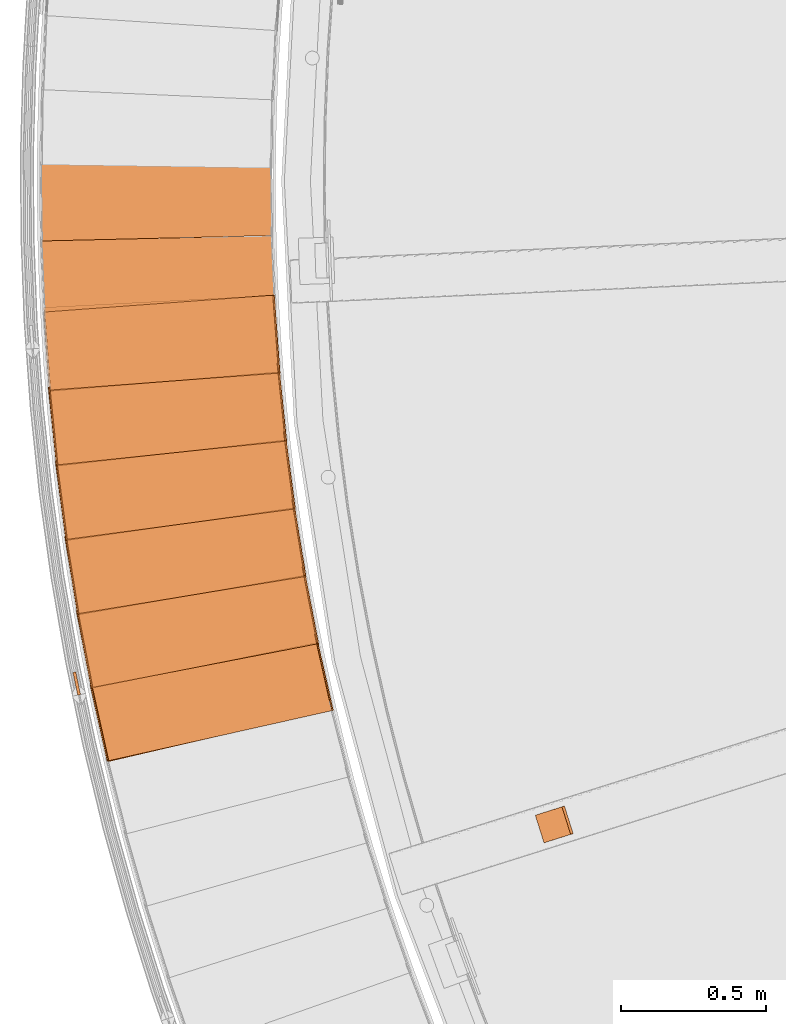
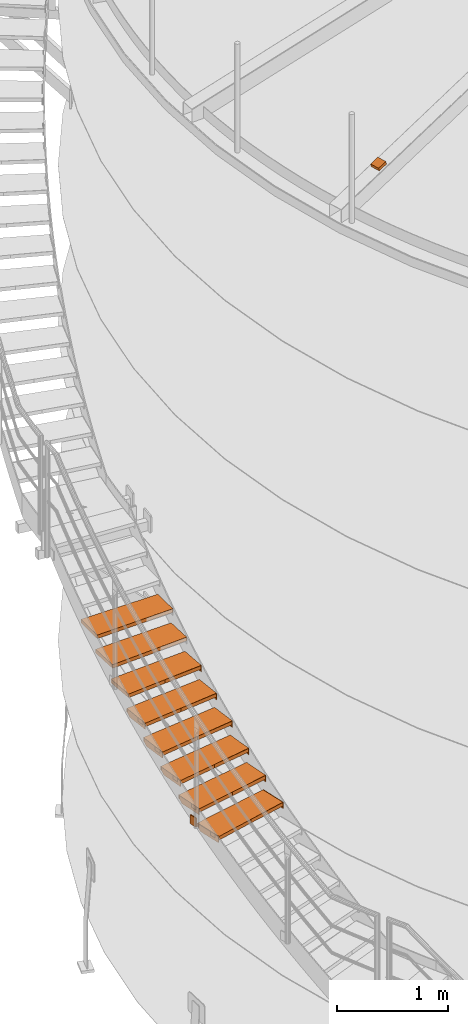
# One storey, part 52 of 126: 27 proxies.
"""IFC2X3 building model written with IfcOpenShell, lengths in millimetres."""

from ifc_helpers import new_model, si_unit, origin, origin_with_axes, place, context, project, spatial, faceted_brep, material, element, save


model = new_model("IFC2X3")

# Units and contexts
context_of_model_1 = context(None, 3, precision=0.1, world=origin())
context_of_model_2 = context(None, 3, precision=0.1, world=origin())
ifc_project = project(units=[si_unit("LENGTHUNIT", "METRE", prefix="MILLI"), si_unit("AREAUNIT", "SQUARE_METRE", prefix="CENTI"), si_unit("VOLUMEUNIT", "CUBIC_METRE", prefix="CENTI"), si_unit("MASSUNIT", "GRAM", prefix="KILO")], contexts=[context_of_model_1, context_of_model_2])

# Site, building, storey
site_placement = place(None, origin_with_axes())
site = spatial("IfcSite", under=ifc_project, at=site_placement, CompositionType="ELEMENT")
building_placement = place(site_placement, origin_with_axes())
building = spatial("IfcBuilding", under=site, at=building_placement, CompositionType="ELEMENT")
storey_placement = place(building_placement, origin_with_axes())
storey = spatial("IfcBuildingStorey", under=building, at=storey_placement, CompositionType="ELEMENT")

# Proxies
ifc_material_1 = material(Name="HOLZ")
proxy_1_placement = place(storey_placement, origin_with_axes())
element("IfcBuildingElementProxy", 1, at=proxy_1_placement, inside=storey, material=ifc_material_1, context=context_of_model_2, shape_type="Brep", body=[
    faceted_brep([(-642.1313, 6282.6158, 3810.5375), (-636.9506, 6256.8076, 3810.5375), (-631.6929, 6231.015, 3810.5375), (-626.3582, 6205.2382, 3810.5375), (-620.9466, 6179.4774, 3810.5375), (-615.4581, 6153.7329, 3810.5375), (-609.8927, 6128.0049, 3810.5375), (-604.2506, 6102.2937, 3810.5375), (-598.5317, 6076.5994, 3810.5375), (-592.7362, 6050.9222, 3810.5375), (-586.864, 6025.2625, 3810.5375), (-580.9152, 5999.6205, 3810.5375), (198.1176, 6181.5762, 3810.5375), (192.1105, 6207.4893, 3810.5375), (186.1894, 6233.4223, 3810.5375), (180.3543, 6259.3747, 3810.5375), (174.6055, 6285.3464, 3810.5375), (168.9428, 6311.337, 3810.5375), (163.3664, 6337.3462, 3810.5375), (157.8763, 6363.3738, 3810.5375), (152.4726, 6389.4195, 3810.5375), (147.1553, 6415.483, 3810.5375), (141.9246, 6441.5639, 3810.5375), (-642.1313, 6282.6158, 3770.5375), (141.9246, 6441.5639, 3770.5375), (147.1553, 6415.483, 3770.5375), (152.4726, 6389.4195, 3770.5375), (157.8763, 6363.3738, 3770.5375), (163.3664, 6337.3462, 3770.5375), (168.9428, 6311.337, 3770.5375), (174.6055, 6285.3464, 3770.5375), (180.3543, 6259.3747, 3770.5375), (186.1894, 6233.4223, 3770.5375), (192.1105, 6207.4893, 3770.5375), (198.1176, 6181.5762, 3770.5375), (-580.9152, 5999.6205, 3770.5375), (-586.864, 6025.2625, 3770.5375), (-592.7362, 6050.9222, 3770.5375), (-598.5317, 6076.5994, 3770.5375), (-604.2506, 6102.2937, 3770.5375), (-609.8927, 6128.0049, 3770.5375), (-615.4581, 6153.7329, 3770.5375), (-620.9466, 6179.4774, 3770.5375), (-626.3582, 6205.2382, 3770.5375), (-631.6929, 6231.015, 3770.5375), (-636.9506, 6256.8076, 3770.5375)], [[[0, 1, 2, 3, 4, 5, 6, 7, 8, 9, 10, 11, 12, 13, 14, 15, 16, 17, 18, 19, 20, 21, 22]], [[23, 24, 25, 26, 27, 28, 29, 30, 31, 32, 33, 34, 35, 36, 37, 38, 39, 40, 41, 42, 43, 44, 45]], [[0, 23, 45, 1]], [[1, 45, 44, 2]], [[2, 44, 43, 3]], [[3, 43, 42, 4]], [[4, 42, 41, 5]], [[5, 41, 40, 6]], [[6, 40, 39, 7]], [[7, 39, 38, 8]], [[8, 38, 37, 9]], [[9, 37, 36, 10]], [[10, 36, 35, 11]], [[11, 35, 34, 12]], [[12, 34, 33, 13]], [[13, 33, 32, 14]], [[14, 32, 31, 15]], [[15, 31, 30, 16]], [[16, 30, 29, 17]], [[17, 29, 28, 18]], [[18, 28, 27, 19]], [[19, 27, 26, 20]], [[20, 26, 25, 21]], [[21, 25, 24, 22]], [[22, 24, 23, 0]]]),
])
proxy_2_placement = place(storey_placement, origin_with_axes())
element("IfcBuildingElementProxy", 2, at=proxy_2_placement, inside=storey, material=ifc_material_1, context=context_of_model_2, shape_type="Brep", body=[
    faceted_brep([(-689.0808, 6537.8783, 3983.7438), (-684.662, 6511.9288, 3983.7438), (-680.1657, 6485.9926, 3983.7438), (-675.592, 6460.0699, 3983.7438), (-670.941, 6434.161, 3983.7438), (-666.2126, 6408.2662, 3983.7438), (-661.4069, 6382.3855, 3983.7438), (-656.524, 6356.5193, 3983.7438), (-651.5639, 6330.6678, 3983.7438), (-646.5266, 6304.8312, 3983.7438), (-641.4123, 6279.0098, 3983.7438), (-636.2208, 6253.2038, 3983.7438), (147.8301, 6412.1509, 3983.7438), (142.5883, 6438.2297, 3983.7438), (137.4331, 6464.3256, 3983.7438), (132.3644, 6490.4386, 3983.7438), (127.3825, 6516.5682, 3983.7438), (122.4872, 6542.7142, 3983.7438), (117.6788, 6568.8763, 3983.7438), (112.9572, 6595.0542, 3983.7438), (108.3224, 6621.2477, 3983.7438), (103.7746, 6647.4563, 3983.7438), (99.3138, 6673.68, 3983.7438), (-689.0808, 6537.8783, 3943.7438), (99.3138, 6673.68, 3943.7438), (103.7746, 6647.4563, 3943.7438), (108.3224, 6621.2477, 3943.7438), (112.9572, 6595.0542, 3943.7438), (117.6788, 6568.8763, 3943.7438), (122.4872, 6542.7142, 3943.7438), (127.3825, 6516.5682, 3943.7438), (132.3644, 6490.4386, 3943.7438), (137.4331, 6464.3256, 3943.7438), (142.5883, 6438.2297, 3943.7438), (147.8301, 6412.1509, 3943.7438), (-636.2208, 6253.2038, 3943.7438), (-641.4123, 6279.0098, 3943.7438), (-646.5266, 6304.8312, 3943.7438), (-651.5639, 6330.6678, 3943.7438), (-656.524, 6356.5193, 3943.7438), (-661.4069, 6382.3855, 3943.7438), (-666.2126, 6408.2662, 3943.7438), (-670.941, 6434.161, 3943.7438), (-675.592, 6460.0699, 3943.7438), (-680.1657, 6485.9926, 3943.7438), (-684.662, 6511.9288, 3943.7438)], [[[0, 1, 2, 3, 4, 5, 6, 7, 8, 9, 10, 11, 12, 13, 14, 15, 16, 17, 18, 19, 20, 21, 22]], [[23, 24, 25, 26, 27, 28, 29, 30, 31, 32, 33, 34, 35, 36, 37, 38, 39, 40, 41, 42, 43, 44, 45]], [[0, 23, 45, 1]], [[1, 45, 44, 2]], [[2, 44, 43, 3]], [[3, 43, 42, 4]], [[4, 42, 41, 5]], [[5, 41, 40, 6]], [[6, 40, 39, 7]], [[7, 39, 38, 8]], [[8, 38, 37, 9]], [[9, 37, 36, 10]], [[10, 36, 35, 11]], [[11, 35, 34, 12]], [[12, 34, 33, 13]], [[13, 33, 32, 14]], [[14, 32, 31, 15]], [[15, 31, 30, 16]], [[16, 30, 29, 17]], [[17, 29, 28, 18]], [[18, 28, 27, 19]], [[19, 27, 26, 20]], [[20, 26, 25, 21]], [[21, 25, 24, 22]], [[22, 24, 23, 0]]]),
])
proxy_3_placement = place(storey_placement, origin_with_axes())
element("IfcBuildingElementProxy", 3, at=proxy_3_placement, inside=storey, material=ifc_material_1, context=context_of_model_2, shape_type="Brep", body=[
    faceted_brep([(-728.4966, 6794.4121, 4156.95), (-724.8435, 6768.3438, 4156.95), (-721.1126, 6742.2865, 4156.95), (-717.3039, 6716.2404, 4156.95), (-713.4175, 6690.2059, 4156.95), (-709.4533, 6664.183, 4156.95), (-705.4115, 6638.1721, 4156.95), (-701.292, 6612.1734, 4156.95), (-697.095, 6586.1871, 4156.95), (-692.8203, 6560.2135, 4156.95), (-688.4682, 6534.2527, 4156.95), (-684.0386, 6508.3051, 4156.95), (104.351, 6644.1059, 4156.95), (99.8791, 6670.3276, 4156.95), (95.4942, 6696.564, 4156.95), (91.1963, 6722.8149, 4156.95), (86.9856, 6749.0798, 4156.95), (82.8621, 6775.3586, 4156.95), (78.8258, 6801.6509, 4156.95), (74.8767, 6827.9564, 4156.95), (71.015, 6854.2749, 4156.95), (67.2405, 6880.6061, 4156.95), (63.5535, 6906.9496, 4156.95), (-728.4966, 6794.4121, 4116.95), (63.5535, 6906.9496, 4116.95), (67.2405, 6880.6061, 4116.95), (71.015, 6854.2749, 4116.95), (74.8767, 6827.9564, 4116.95), (78.8258, 6801.6509, 4116.95), (82.8621, 6775.3586, 4116.95), (86.9856, 6749.0798, 4116.95), (91.1963, 6722.8149, 4116.95), (95.4942, 6696.564, 4116.95), (99.8791, 6670.3276, 4116.95), (104.351, 6644.1059, 4116.95), (-684.0386, 6508.3051, 4116.95), (-688.4682, 6534.2527, 4116.95), (-692.8203, 6560.2135, 4116.95), (-697.095, 6586.1871, 4116.95), (-701.292, 6612.1734, 4116.95), (-705.4115, 6638.1721, 4116.95), (-709.4533, 6664.183, 4116.95), (-713.4175, 6690.2059, 4116.95), (-717.3039, 6716.2404, 4116.95), (-721.1126, 6742.2865, 4116.95), (-724.8435, 6768.3438, 4116.95)], [[[0, 1, 2, 3, 4, 5, 6, 7, 8, 9, 10, 11, 12, 13, 14, 15, 16, 17, 18, 19, 20, 21, 22]], [[23, 24, 25, 26, 27, 28, 29, 30, 31, 32, 33, 34, 35, 36, 37, 38, 39, 40, 41, 42, 43, 44, 45]], [[0, 23, 45, 1]], [[1, 45, 44, 2]], [[2, 44, 43, 3]], [[3, 43, 42, 4]], [[4, 42, 41, 5]], [[5, 41, 40, 6]], [[6, 40, 39, 7]], [[7, 39, 38, 8]], [[8, 38, 37, 9]], [[9, 37, 36, 10]], [[10, 36, 35, 11]], [[11, 35, 34, 12]], [[12, 34, 33, 13]], [[13, 33, 32, 14]], [[14, 32, 31, 15]], [[15, 31, 30, 16]], [[16, 30, 29, 17]], [[17, 29, 28, 18]], [[18, 28, 27, 19]], [[19, 27, 26, 20]], [[20, 26, 25, 21]], [[21, 25, 24, 22]], [[22, 24, 23, 0]]]),
])
proxy_4_placement = place(storey_placement, origin_with_axes())
element("IfcBuildingElementProxy", 4, at=proxy_4_placement, inside=storey, material=ifc_material_1, context=context_of_model_2, shape_type="Brep", body=[
    faceted_brep([(-760.3447, 7051.9949, 4330.1563), (-757.4605, 7025.8303, 4330.1563), (-754.4981, 6999.6745, 4330.1563), (-751.4577, 6973.5276, 4330.1563), (-748.3392, 6947.39, 4330.1563), (-745.1428, 6921.2617, 4330.1563), (-741.8683, 6895.1431, 4330.1563), (-738.5158, 6869.0344, 4330.1563), (-735.0855, 6842.9359, 4330.1563), (-731.5772, 6816.8477, 4330.1563), (-727.991, 6790.7701, 4330.1563), (-724.3271, 6764.7033, 4330.1563), (67.7181, 6877.2401, 4330.1563), (64.0199, 6903.5821, 4330.1563), (60.4091, 6929.9362, 4330.1563), (56.8858, 6956.3022, 4330.1563), (53.45, 6982.6797, 4330.1563), (50.1017, 7009.0684, 4330.1563), (46.841, 7035.4681, 4330.1563), (43.6679, 7061.8785, 4330.1563), (40.5825, 7088.2993, 4330.1563), (37.5847, 7114.7301, 4330.1563), (34.6746, 7141.1708, 4330.1563), (-760.3447, 7051.9949, 4290.1563), (34.6746, 7141.1708, 4290.1563), (37.5847, 7114.7301, 4290.1563), (40.5825, 7088.2993, 4290.1563), (43.6679, 7061.8785, 4290.1563), (46.841, 7035.4681, 4290.1563), (50.1017, 7009.0684, 4290.1563), (53.45, 6982.6797, 4290.1563), (56.8858, 6956.3022, 4290.1563), (60.4091, 6929.9362, 4290.1563), (64.0199, 6903.5821, 4290.1563), (67.7181, 6877.2401, 4290.1563), (-724.3271, 6764.7033, 4290.1563), (-727.991, 6790.7701, 4290.1563), (-731.5772, 6816.8477, 4290.1563), (-735.0855, 6842.9359, 4290.1563), (-738.5158, 6869.0344, 4290.1563), (-741.8683, 6895.1431, 4290.1563), (-745.1428, 6921.2617, 4290.1563), (-748.3392, 6947.39, 4290.1563), (-751.4577, 6973.5276, 4290.1563), (-754.4981, 6999.6745, 4290.1563), (-757.4605, 7025.8303, 4290.1563)], [[[0, 1, 2, 3, 4, 5, 6, 7, 8, 9, 10, 11, 12, 13, 14, 15, 16, 17, 18, 19, 20, 21, 22]], [[23, 24, 25, 26, 27, 28, 29, 30, 31, 32, 33, 34, 35, 36, 37, 38, 39, 40, 41, 42, 43, 44, 45]], [[0, 23, 45, 1]], [[1, 45, 44, 2]], [[2, 44, 43, 3]], [[3, 43, 42, 4]], [[4, 42, 41, 5]], [[5, 41, 40, 6]], [[6, 40, 39, 7]], [[7, 39, 38, 8]], [[8, 38, 37, 9]], [[9, 37, 36, 10]], [[10, 36, 35, 11]], [[11, 35, 34, 12]], [[12, 34, 33, 13]], [[13, 33, 32, 14]], [[14, 32, 31, 15]], [[15, 31, 30, 16]], [[16, 30, 29, 17]], [[17, 29, 28, 18]], [[18, 28, 27, 19]], [[19, 27, 26, 20]], [[20, 26, 25, 21]], [[21, 25, 24, 22]], [[22, 24, 23, 0]]]),
])
proxy_5_placement = place(storey_placement, origin_with_axes())
element("IfcBuildingElementProxy", 5, at=proxy_5_placement, inside=storey, material=ifc_material_1, context=context_of_model_2, shape_type="Brep", body=[
    faceted_brep([(-784.5974, 7310.4035, 4503.3625), (-782.4845, 7284.1654, 4503.3625), (-780.2933, 7257.9337, 4503.3625), (-778.0238, 7231.7087, 4503.3625), (-775.676, 7205.4905, 4503.3625), (-773.25, 7179.2795, 4503.3625), (-770.7457, 7153.0759, 4503.3625), (-768.1632, 7126.8798, 4503.3625), (-765.5024, 7100.6916, 4503.3625), (-762.7636, 7074.5114, 4503.3625), (-759.9465, 7048.3395, 4503.3625), (-757.0514, 7022.1762, 4503.3625), (37.9629, 7111.3516, 4503.3625), (35.0417, 7137.791, 4503.3625), (32.2082, 7164.24, 4503.3625), (29.4624, 7190.6982, 4503.3625), (26.8045, 7217.1654, 4503.3625), (24.2344, 7243.6413, 4503.3625), (21.7521, 7270.1255, 4503.3625), (19.3578, 7296.6178, 4503.3625), (17.0513, 7323.118, 4503.3625), (14.8328, 7349.6256, 4503.3625), (12.7023, 7376.1405, 4503.3625), (-784.5974, 7310.4035, 4463.3625), (12.7023, 7376.1405, 4463.3625), (14.8328, 7349.6256, 4463.3625), (17.0513, 7323.118, 4463.3625), (19.3578, 7296.6178, 4463.3625), (21.7521, 7270.1255, 4463.3625), (24.2344, 7243.6413, 4463.3625), (26.8045, 7217.1654, 4463.3625), (29.4624, 7190.6982, 4463.3625), (32.2082, 7164.24, 4463.3625), (35.0417, 7137.791, 4463.3625), (37.9629, 7111.3516, 4463.3625), (-757.0514, 7022.1762, 4463.3625), (-759.9465, 7048.3395, 4463.3625), (-762.7636, 7074.5114, 4463.3625), (-765.5024, 7100.6916, 4463.3625), (-768.1632, 7126.8798, 4463.3625), (-770.7457, 7153.0759, 4463.3625), (-773.25, 7179.2795, 4463.3625), (-775.676, 7205.4905, 4463.3625), (-778.0238, 7231.7087, 4463.3625), (-780.2933, 7257.9337, 4463.3625), (-782.4845, 7284.1654, 4463.3625)], [[[0, 1, 2, 3, 4, 5, 6, 7, 8, 9, 10, 11, 12, 13, 14, 15, 16, 17, 18, 19, 20, 21, 22]], [[23, 24, 25, 26, 27, 28, 29, 30, 31, 32, 33, 34, 35, 36, 37, 38, 39, 40, 41, 42, 43, 44, 45]], [[0, 23, 45, 1]], [[1, 45, 44, 2]], [[2, 44, 43, 3]], [[3, 43, 42, 4]], [[4, 42, 41, 5]], [[5, 41, 40, 6]], [[6, 40, 39, 7]], [[7, 39, 38, 8]], [[8, 38, 37, 9]], [[9, 37, 36, 10]], [[10, 36, 35, 11]], [[11, 35, 34, 12]], [[12, 34, 33, 13]], [[13, 33, 32, 14]], [[14, 32, 31, 15]], [[15, 31, 30, 16]], [[16, 30, 29, 17]], [[17, 29, 28, 18]], [[18, 28, 27, 19]], [[19, 27, 26, 20]], [[20, 26, 25, 21]], [[21, 25, 24, 22]], [[22, 24, 23, 0]]]),
])
proxy_6_placement = place(storey_placement, origin_with_axes())
element("IfcBuildingElementProxy", 6, at=proxy_6_placement, inside=storey, material=ifc_material_1, context=context_of_model_2, shape_type="Brep", body=[
    faceted_brep([(-801.2337, 7569.414, 4676.5688), (-799.894, 7543.125, 4676.5688), (-798.4759, 7516.8402, 4676.5688), (-796.9792, 7490.5597, 4676.5688), (-795.4042, 7464.2839, 4676.5688), (-793.7506, 7438.0128, 4676.5688), (-792.0187, 7411.7468, 4676.5688), (-790.2083, 7385.4861, 4676.5688), (-788.3196, 7359.2309, 4676.5688), (-786.3525, 7332.9815, 4676.5688), (-784.307, 7306.738, 4676.5688), (-782.1832, 7280.5008, 4676.5688), (15.1114, 7346.2374, 4676.5688), (12.9697, 7372.7513, 4676.5688), (10.9159, 7399.2723, 4676.5688), (8.9501, 7425.7998, 4676.5688), (7.0723, 7452.3338, 4676.5688), (5.2826, 7478.8738, 4676.5688), (3.5809, 7505.4197, 4676.5688), (1.9674, 7531.971, 4676.5688), (0.4419, 7558.5276, 4676.5688), (-0.9954, 7585.089, 4676.5688), (-2.3446, 7611.6551, 4676.5688), (-801.2337, 7569.414, 4636.5688), (-2.3446, 7611.6551, 4636.5688), (-0.9954, 7585.089, 4636.5688), (0.4419, 7558.5276, 4636.5688), (1.9674, 7531.971, 4636.5688), (3.5809, 7505.4197, 4636.5688), (5.2826, 7478.8738, 4636.5688), (7.0723, 7452.3338, 4636.5688), (8.9501, 7425.7998, 4636.5688), (10.9159, 7399.2723, 4636.5688), (12.9697, 7372.7513, 4636.5688), (15.1114, 7346.2374, 4636.5688), (-782.1832, 7280.5008, 4636.5688), (-784.307, 7306.738, 4636.5688), (-786.3525, 7332.9815, 4636.5688), (-788.3196, 7359.2309, 4636.5688), (-790.2083, 7385.4861, 4636.5688), (-792.0187, 7411.7468, 4636.5688), (-793.7506, 7438.0128, 4636.5688), (-795.4042, 7464.2839, 4636.5688), (-796.9792, 7490.5597, 4636.5688), (-798.4759, 7516.8402, 4636.5688), (-799.894, 7543.125, 4636.5688)], [[[0, 1, 2, 3, 4, 5, 6, 7, 8, 9, 10, 11, 12, 13, 14, 15, 16, 17, 18, 19, 20, 21, 22]], [[23, 24, 25, 26, 27, 28, 29, 30, 31, 32, 33, 34, 35, 36, 37, 38, 39, 40, 41, 42, 43, 44, 45]], [[0, 23, 45, 1]], [[1, 45, 44, 2]], [[2, 44, 43, 3]], [[3, 43, 42, 4]], [[4, 42, 41, 5]], [[5, 41, 40, 6]], [[6, 40, 39, 7]], [[7, 39, 38, 8]], [[8, 38, 37, 9]], [[9, 37, 36, 10]], [[10, 36, 35, 11]], [[11, 35, 34, 12]], [[12, 34, 33, 13]], [[13, 33, 32, 14]], [[14, 32, 31, 15]], [[15, 31, 30, 16]], [[16, 30, 29, 17]], [[17, 29, 28, 18]], [[18, 28, 27, 19]], [[19, 27, 26, 20]], [[20, 26, 25, 21]], [[21, 25, 24, 22]], [[22, 24, 23, 0]]]),
])
proxy_7_placement = place(storey_placement, origin_with_axes())
element("IfcBuildingElementProxy", 7, at=proxy_7_placement, inside=storey, material=ifc_material_1, context=context_of_model_2, shape_type="Brep", body=[
    faceted_brep([(-810.2392, 7828.8019, 4849.775), (-809.6739, 7802.4849, 4849.775), (-809.03, 7776.1697, 4849.775), (-808.3075, 7749.8566, 4849.775), (-807.5065, 7723.5458, 4849.775), (-806.627, 7697.2374, 4849.775), (-805.6689, 7670.9318, 4849.775), (-804.6322, 7644.6292, 4849.775), (-803.5171, 7618.3298, 4849.775), (-802.3234, 7592.0338, 4849.775), (-801.0513, 7565.7415, 4849.775), (-799.7006, 7539.4532, 4849.775), (-0.8166, 7581.6941, 4849.775), (-2.1771, 7608.2596, 4849.775), (-3.4494, 7634.8294, 4849.775), (-4.6335, 7661.4034, 4849.775), (-5.7295, 7687.9811, 4849.775), (-6.7372, 7714.5623, 4849.775), (-7.6568, 7741.1468, 4849.775), (-8.4882, 7767.7341, 4849.775), (-9.2313, 7794.324, 4849.775), (-9.8862, 7820.9163, 4849.775), (-10.4529, 7847.5106, 4849.775), (-810.2392, 7828.8019, 4809.775), (-10.4529, 7847.5106, 4809.775), (-9.8862, 7820.9163, 4809.775), (-9.2313, 7794.324, 4809.775), (-8.4882, 7767.7341, 4809.775), (-7.6568, 7741.1468, 4809.775), (-6.7372, 7714.5623, 4809.775), (-5.7295, 7687.9811, 4809.775), (-4.6335, 7661.4034, 4809.775), (-3.4494, 7634.8294, 4809.775), (-2.1771, 7608.2596, 4809.775), (-0.8166, 7581.6941, 4809.775), (-799.7006, 7539.4532, 4809.775), (-801.0513, 7565.7415, 4809.775), (-802.3234, 7592.0338, 4809.775), (-803.5171, 7618.3298, 4809.775), (-804.6322, 7644.6292, 4809.775), (-805.6689, 7670.9318, 4809.775), (-806.627, 7697.2374, 4809.775), (-807.5065, 7723.5458, 4809.775), (-808.3075, 7749.8566, 4809.775), (-809.03, 7776.1697, 4809.775), (-809.6739, 7802.4849, 4809.775)], [[[0, 1, 2, 3, 4, 5, 6, 7, 8, 9, 10, 11, 12, 13, 14, 15, 16, 17, 18, 19, 20, 21, 22]], [[23, 24, 25, 26, 27, 28, 29, 30, 31, 32, 33, 34, 35, 36, 37, 38, 39, 40, 41, 42, 43, 44, 45]], [[0, 23, 45, 1]], [[1, 45, 44, 2]], [[2, 44, 43, 3]], [[3, 43, 42, 4]], [[4, 42, 41, 5]], [[5, 41, 40, 6]], [[6, 40, 39, 7]], [[7, 39, 38, 8]], [[8, 38, 37, 9]], [[9, 37, 36, 10]], [[10, 36, 35, 11]], [[11, 35, 34, 12]], [[12, 34, 33, 13]], [[13, 33, 32, 14]], [[14, 32, 31, 15]], [[15, 31, 30, 16]], [[16, 30, 29, 17]], [[17, 29, 28, 18]], [[18, 28, 27, 19]], [[19, 27, 26, 20]], [[20, 26, 25, 21]], [[21, 25, 24, 22]], [[22, 24, 23, 0]]]),
])
proxy_8_placement = place(storey_placement, origin_with_axes())
element("IfcBuildingElementProxy", 8, at=proxy_8_placement, inside=storey, material=ifc_material_1, context=context_of_model_2, shape_type="Brep", body=[
    faceted_brep([(-811.606, 8088.3425, 5022.9813), (-811.8156, 8062.0203, 5022.9813), (-811.9465, 8035.6976, 5022.9813), (-811.9989, 8009.3746, 5022.9813), (-811.9726, 7983.0515, 5022.9813), (-811.8678, 7956.7287, 5022.9813), (-811.6844, 7930.4063, 5022.9813), (-811.4224, 7904.0846, 5022.9813), (-811.0818, 7877.7637, 5022.9813), (-810.6627, 7851.444, 5022.9813), (-810.1649, 7825.1257, 5022.9813), (-809.5886, 7798.809, 5022.9813), (-9.8074, 7817.5175, 5022.9813), (-10.3854, 7844.1116, 5022.9813), (-10.8751, 7870.7074, 5022.9813), (-11.2765, 7897.3047, 5022.9813), (-11.5897, 7923.9031, 5022.9813), (-11.8147, 7950.5025, 5022.9813), (-11.9514, 7977.1025, 5022.9813), (-11.9998, 8003.7027, 5022.9813), (-11.96, 8030.303, 5022.9813), (-11.8319, 8056.903, 5022.9813), (-11.6156, 8083.5025, 5022.9813), (-811.606, 8088.3425, 4982.9813), (-11.6156, 8083.5025, 4982.9813), (-11.8319, 8056.903, 4982.9813), (-11.96, 8030.303, 4982.9813), (-11.9998, 8003.7027, 4982.9813), (-11.9514, 7977.1025, 4982.9813), (-11.8147, 7950.5025, 4982.9813), (-11.5897, 7923.9031, 4982.9813), (-11.2765, 7897.3047, 4982.9813), (-10.8751, 7870.7074, 4982.9813), (-10.3854, 7844.1116, 4982.9813), (-9.8074, 7817.5175, 4982.9813), (-809.5886, 7798.809, 4982.9813), (-810.1649, 7825.1257, 4982.9813), (-810.6627, 7851.444, 4982.9813), (-811.0818, 7877.7637, 4982.9813), (-811.4224, 7904.0846, 4982.9813), (-811.6844, 7930.4063, 4982.9813), (-811.8678, 7956.7287, 4982.9813), (-811.9726, 7983.0515, 4982.9813), (-811.9989, 8009.3746, 4982.9813), (-811.9465, 8035.6976, 4982.9813), (-811.8156, 8062.0203, 4982.9813)], [[[0, 1, 2, 3, 4, 5, 6, 7, 8, 9, 10, 11, 12, 13, 14, 15, 16, 17, 18, 19, 20, 21, 22]], [[23, 24, 25, 26, 27, 28, 29, 30, 31, 32, 33, 34, 35, 36, 37, 38, 39, 40, 41, 42, 43, 44, 45]], [[0, 23, 45, 1]], [[1, 45, 44, 2]], [[2, 44, 43, 3]], [[3, 43, 42, 4]], [[4, 42, 41, 5]], [[5, 41, 40, 6]], [[6, 40, 39, 7]], [[7, 39, 38, 8]], [[8, 38, 37, 9]], [[9, 37, 36, 10]], [[10, 36, 35, 11]], [[11, 35, 34, 12]], [[12, 34, 33, 13]], [[13, 33, 32, 14]], [[14, 32, 31, 15]], [[15, 31, 30, 16]], [[16, 30, 29, 17]], [[17, 29, 28, 18]], [[18, 28, 27, 19]], [[19, 27, 26, 20]], [[20, 26, 25, 21]], [[21, 25, 24, 22]], [[22, 24, 23, 0]]]),
])
ifc_material_2 = material(Name="S235JRG2")
proxy_9_placement = place(storey_placement, origin_with_axes())
element("IfcBuildingElementProxy", 9, at=proxy_9_placement, inside=storey, material=ifc_material_2, context=context_of_model_2, shape_type="Brep", body=[
    faceted_brep([(-576.8149, 6004.1136, 3770.31), (-576.8149, 6004.1136, 3810.31), (-635.9284, 6267.5631, 3810.31), (-635.9284, 6267.5631, 3770.31), (194.0186, 6177.0753, 3770.31), (134.9051, 6440.5247, 3770.31), (134.9051, 6440.5247, 3810.31), (194.0186, 6177.0753, 3810.31)], [[[0, 1, 2, 3]], [[4, 5, 6, 7]], [[0, 4, 7, 1]], [[1, 7, 6, 2]], [[2, 6, 5, 3]], [[3, 5, 4, 0]]]),
])
proxy_10_placement = place(storey_placement, origin_with_axes())
element("IfcBuildingElementProxy", 10, at=proxy_10_placement, inside=storey, material=ifc_material_2, context=context_of_model_2, shape_type="Brep", body=[
    faceted_brep([(194.0186, 6177.0753, 3740.31), (198.8973, 6178.17, 3740.31), (198.8973, 6178.17, 3810.31), (194.0186, 6177.0753, 3810.31), (134.9051, 6440.5247, 3810.31), (139.7838, 6441.6194, 3810.31), (139.7838, 6441.6194, 3770.31), (134.9051, 6440.5247, 3770.31), (141.4733, 6411.2526, 3740.31), (146.352, 6412.3473, 3740.31)], [[[0, 1, 2, 3]], [[4, 5, 6, 7]], [[0, 8, 9, 1]], [[1, 9, 6, 5, 2]], [[2, 5, 4, 3]], [[0, 3, 4, 7, 8]], [[6, 9, 8, 7]]]),
])
proxy_11_placement = place(storey_placement, origin_with_axes())
element("IfcBuildingElementProxy", 11, at=proxy_11_placement, inside=storey, material=ifc_material_2, context=context_of_model_2, shape_type="Brep", body=[
    faceted_brep([(-581.6936, 6003.0189, 3740.31), (-576.8149, 6004.1136, 3740.31), (-576.8149, 6004.1136, 3810.31), (-581.6936, 6003.0189, 3810.31), (-640.8071, 6266.4684, 3810.31), (-635.9284, 6267.5631, 3810.31), (-635.9284, 6267.5631, 3770.31), (-640.8071, 6266.4684, 3770.31), (-634.2389, 6237.1962, 3740.31), (-629.3602, 6238.2909, 3740.31)], [[[0, 1, 2, 3]], [[4, 5, 6, 7]], [[0, 8, 9, 1]], [[1, 9, 6, 5, 2]], [[2, 5, 4, 3]], [[0, 3, 4, 7, 8]], [[6, 9, 8, 7]]]),
])
proxy_12_placement = place(storey_placement, origin_with_axes())
element("IfcBuildingElementProxy", 12, at=proxy_12_placement, inside=storey, material=ifc_material_2, context=context_of_model_2, shape_type="Brep", body=[
    faceted_brep([(-631.9899, 6257.5736, 3943.47), (-631.9899, 6257.5736, 3983.47), (-683.3235, 6522.6487, 3983.47), (-683.3235, 6522.6487, 3943.47), (143.6005, 6407.7719, 3943.47), (92.2669, 6672.8471, 3943.47), (92.2669, 6672.8471, 3983.47), (143.6005, 6407.7719, 3983.47)], [[[0, 1, 2, 3]], [[4, 5, 6, 7]], [[0, 4, 7, 1]], [[1, 7, 6, 2]], [[2, 6, 5, 3]], [[3, 5, 4, 0]]]),
])
proxy_13_placement = place(storey_placement, origin_with_axes())
element("IfcBuildingElementProxy", 13, at=proxy_13_placement, inside=storey, material=ifc_material_2, context=context_of_model_2, shape_type="Brep", body=[
    faceted_brep([(143.6005, 6407.7719, 3913.47), (148.5093, 6408.7226, 3913.47), (148.5093, 6408.7226, 3983.47), (143.6005, 6407.7719, 3983.47), (92.2669, 6672.8471, 3983.47), (97.1757, 6673.7978, 3983.47), (97.1757, 6673.7978, 3943.47), (92.2669, 6672.8471, 3943.47), (97.9706, 6643.3943, 3913.47), (102.8794, 6644.345, 3913.47)], [[[0, 1, 2, 3]], [[4, 5, 6, 7]], [[0, 8, 9, 1]], [[1, 9, 6, 5, 2]], [[2, 5, 4, 3]], [[0, 3, 4, 7, 8]], [[6, 9, 8, 7]]]),
])
proxy_14_placement = place(storey_placement, origin_with_axes())
element("IfcBuildingElementProxy", 14, at=proxy_14_placement, inside=storey, material=ifc_material_2, context=context_of_model_2, shape_type="Brep", body=[
    faceted_brep([(-636.8987, 6256.6229, 3913.47), (-631.9899, 6257.5736, 3913.47), (-631.9899, 6257.5736, 3983.47), (-636.8987, 6256.6229, 3983.47), (-688.2323, 6521.6981, 3983.47), (-683.3235, 6522.6487, 3983.47), (-683.3235, 6522.6487, 3943.47), (-688.2323, 6521.6981, 3943.47), (-682.5285, 6492.2453, 3913.47), (-677.6197, 6493.1959, 3913.47)], [[[0, 1, 2, 3]], [[4, 5, 6, 7]], [[0, 8, 9, 1]], [[1, 9, 6, 5, 2]], [[2, 5, 4, 3]], [[0, 3, 4, 7, 8]], [[6, 9, 8, 7]]]),
])
proxy_15_placement = place(storey_placement, origin_with_axes())
element("IfcBuildingElementProxy", 15, at=proxy_15_placement, inside=storey, material=ifc_material_2, context=context_of_model_2, shape_type="Brep", body=[
    faceted_brep([(-679.6807, 6512.5476, 4116.63), (-679.6807, 6512.5476, 4156.63), (-723.19, 6779.0189, 4156.63), (-723.19, 6779.0189, 4116.63), (99.9945, 6639.8526, 4116.63), (56.4852, 6906.3239, 4116.63), (56.4852, 6906.3239, 4156.63), (99.9945, 6639.8526, 4156.63)], [[[0, 1, 2, 3]], [[4, 5, 6, 7]], [[0, 4, 7, 1]], [[1, 7, 6, 2]], [[2, 6, 5, 3]], [[3, 5, 4, 0]]]),
])
proxy_16_placement = place(storey_placement, origin_with_axes())
element("IfcBuildingElementProxy", 16, at=proxy_16_placement, inside=storey, material=ifc_material_2, context=context_of_model_2, shape_type="Brep", body=[
    faceted_brep([(99.9945, 6639.8526, 4086.63), (104.9292, 6640.6583, 4086.63), (104.9292, 6640.6583, 4156.63), (99.9945, 6639.8526, 4156.63), (56.4852, 6906.3239, 4156.63), (61.4199, 6907.1296, 4156.63), (61.4199, 6907.1296, 4116.63), (56.4852, 6906.3239, 4116.63), (61.3196, 6876.716, 4086.63), (66.2542, 6877.5217, 4086.63)], [[[0, 1, 2, 3]], [[4, 5, 6, 7]], [[0, 8, 9, 1]], [[1, 9, 6, 5, 2]], [[2, 5, 4, 3]], [[0, 3, 4, 7, 8]], [[6, 9, 8, 7]]]),
])
proxy_17_placement = place(storey_placement, origin_with_axes())
element("IfcBuildingElementProxy", 17, at=proxy_17_placement, inside=storey, material=ifc_material_2, context=context_of_model_2, shape_type="Brep", body=[
    faceted_brep([(-684.6154, 6511.7419, 4086.63), (-679.6807, 6512.5476, 4086.63), (-679.6807, 6512.5476, 4156.63), (-684.6154, 6511.7419, 4156.63), (-728.1246, 6778.2132, 4156.63), (-723.19, 6779.0189, 4156.63), (-723.19, 6779.0189, 4116.63), (-728.1246, 6778.2132, 4116.63), (-723.2903, 6748.6053, 4086.63), (-718.3556, 6749.411, 4086.63)], [[[0, 1, 2, 3]], [[4, 5, 6, 7]], [[0, 8, 9, 1]], [[1, 9, 6, 5, 2]], [[2, 5, 4, 3]], [[0, 3, 4, 7, 8]], [[6, 9, 8, 7]]]),
])
proxy_18_placement = place(storey_placement, origin_with_axes())
element("IfcBuildingElementProxy", 18, at=proxy_18_placement, inside=storey, material=ifc_material_2, context=context_of_model_2, shape_type="Brep", body=[
    faceted_brep([(-719.8461, 6768.815, 4289.79), (-719.8461, 6768.815, 4329.79), (-755.4934, 7036.4514, 4329.79), (-755.4934, 7036.4514, 4289.79), (63.2383, 6873.1162, 4289.79), (27.5911, 7140.7527, 4289.79), (27.5911, 7140.7527, 4329.79), (63.2383, 6873.1162, 4329.79)], [[[0, 1, 2, 3]], [[4, 5, 6, 7]], [[0, 4, 7, 1]], [[1, 7, 6, 2]], [[2, 6, 5, 3]], [[3, 5, 4, 0]]]),
])
proxy_19_placement = place(storey_placement, origin_with_axes())
element("IfcBuildingElementProxy", 19, at=proxy_19_placement, inside=storey, material=ifc_material_2, context=context_of_model_2, shape_type="Brep", body=[
    faceted_brep([(63.2383, 6873.1162, 4259.79), (68.1946, 6873.7763, 4259.79), (68.1946, 6873.7763, 4329.79), (63.2383, 6873.1162, 4329.79), (27.5911, 7140.7527, 4329.79), (32.5473, 7141.4128, 4329.79), (32.5473, 7141.4128, 4289.79), (27.5911, 7140.7527, 4289.79), (31.5519, 7111.0153, 4259.79), (36.5081, 7111.6754, 4259.79)], [[[0, 1, 2, 3]], [[4, 5, 6, 7]], [[0, 8, 9, 1]], [[1, 9, 6, 5, 2]], [[2, 5, 4, 3]], [[0, 3, 4, 7, 8]], [[6, 9, 8, 7]]]),
])
proxy_20_placement = place(storey_placement, origin_with_axes())
element("IfcBuildingElementProxy", 20, at=proxy_20_placement, inside=storey, material=ifc_material_2, context=context_of_model_2, shape_type="Brep", body=[
    faceted_brep([(-724.8023, 6768.1548, 4259.79), (-719.8461, 6768.815, 4259.79), (-719.8461, 6768.815, 4329.79), (-724.8023, 6768.1548, 4329.79), (-760.4496, 7035.7913, 4329.79), (-755.4934, 7036.4514, 4329.79), (-755.4934, 7036.4514, 4289.79), (-760.4496, 7035.7913, 4289.79), (-756.4888, 7006.0539, 4259.79), (-751.5325, 7006.7141, 4259.79)], [[[0, 1, 2, 3]], [[4, 5, 6, 7]], [[0, 8, 9, 1]], [[1, 9, 6, 5, 2]], [[2, 5, 4, 3]], [[0, 3, 4, 7, 8]], [[6, 9, 8, 7]]]),
])
proxy_21_placement = place(storey_placement, origin_with_axes())
element("IfcBuildingElementProxy", 21, at=proxy_21_placement, inside=storey, material=ifc_material_2, context=context_of_model_2, shape_type="Brep", body=[
    faceted_brep([(-752.4513, 7026.1535, 4462.95), (-752.4513, 7026.1535, 4502.95), (-780.2056, 7294.7232, 4502.95), (-780.2056, 7294.7232, 4462.95), (33.3639, 7107.3606, 4462.95), (5.6095, 7375.9303, 4462.95), (5.6095, 7375.9303, 4502.95), (33.3639, 7107.3606, 4502.95)], [[[0, 1, 2, 3]], [[4, 5, 6, 7]], [[0, 4, 7, 1]], [[1, 7, 6, 2]], [[2, 6, 5, 3]], [[3, 5, 4, 0]]]),
])
proxy_22_placement = place(storey_placement, origin_with_axes())
element("IfcBuildingElementProxy", 22, at=proxy_22_placement, inside=storey, material=ifc_material_2, context=context_of_model_2, shape_type="Brep", body=[
    faceted_brep([(33.3639, 7107.3606, 4432.95), (38.3374, 7107.8746, 4432.95), (38.3374, 7107.8746, 4502.95), (33.3639, 7107.3606, 4502.95), (5.6095, 7375.9303, 4502.95), (10.5831, 7376.4443, 4502.95), (10.5831, 7376.4443, 4462.95), (5.6095, 7375.9303, 4462.95), (8.6934, 7346.0892, 4432.95), (13.6669, 7346.6032, 4432.95)], [[[0, 1, 2, 3]], [[4, 5, 6, 7]], [[0, 8, 9, 1]], [[1, 9, 6, 5, 2]], [[2, 5, 4, 3]], [[0, 3, 4, 7, 8]], [[6, 9, 8, 7]]]),
])
proxy_23_placement = place(storey_placement, origin_with_axes())
element("IfcBuildingElementProxy", 23, at=proxy_23_placement, inside=storey, material=ifc_material_2, context=context_of_model_2, shape_type="Brep", body=[
    faceted_brep([(-757.4248, 7025.6395, 4432.95), (-752.4513, 7026.1535, 4432.95), (-752.4513, 7026.1535, 4502.95), (-757.4248, 7025.6395, 4502.95), (-785.1791, 7294.2092, 4502.95), (-780.2056, 7294.7232, 4502.95), (-780.2056, 7294.7232, 4462.95), (-785.1791, 7294.2092, 4462.95), (-782.0953, 7264.3682, 4432.95), (-777.1218, 7264.8821, 4432.95)], [[[0, 1, 2, 3]], [[4, 5, 6, 7]], [[0, 8, 9, 1]], [[1, 9, 6, 5, 2]], [[2, 5, 4, 3]], [[0, 3, 4, 7, 8]], [[6, 9, 8, 7]]]),
])
proxy_24_placement = place(storey_placement, origin_with_axes())
element("IfcBuildingElementProxy", 24, at=proxy_24_placement, inside=storey, material=ifc_material_2, context=context_of_model_2, shape_type="Brep", body=[
    faceted_brep([(-777.4679, 7284.3402, 4636.11), (-777.4679, 7284.3402, 4676.11), (-797.3052, 7553.6105, 4676.11), (-797.3052, 7553.6105, 4636.11), (10.397, 7342.3828, 4636.11), (-9.4404, 7611.6531, 4636.11), (-9.4404, 7611.6531, 4676.11), (10.397, 7342.3828, 4676.11)], [[[0, 1, 2, 3]], [[4, 5, 6, 7]], [[0, 4, 7, 1]], [[1, 7, 6, 2]], [[2, 6, 5, 3]], [[3, 5, 4, 0]]]),
])
proxy_25_placement = place(storey_placement, origin_with_axes())
element("IfcBuildingElementProxy", 25, at=proxy_25_placement, inside=storey, material=ifc_material_2, context=context_of_model_2, shape_type="Brep", body=[
    faceted_brep([(10.397, 7342.3828, 4606.11), (15.3835, 7342.7502, 4606.11), (15.3835, 7342.7502, 4676.11), (10.397, 7342.3828, 4676.11), (-9.4404, 7611.6531, 4676.11), (-4.4539, 7612.0204, 4676.11), (-4.4539, 7612.0204, 4636.11), (-9.4404, 7611.6531, 4636.11), (-7.2362, 7581.7342, 4606.11), (-2.2497, 7582.1015, 4606.11)], [[[0, 1, 2, 3]], [[4, 5, 6, 7]], [[0, 8, 9, 1]], [[1, 9, 6, 5, 2]], [[2, 5, 4, 3]], [[0, 3, 4, 7, 8]], [[6, 9, 8, 7]]]),
])
ifc_material_3 = material(Name="STAHL")
proxy_26_placement = place(storey_placement, origin_with_axes())
element("IfcBuildingElementProxy", 26, at=proxy_26_placement, inside=storey, material=ifc_material_3, Name="profile", context=context_of_model_2, shape_type="Brep", body=[
    faceted_brep([(953.0, 5797.2, 10838.4), (950.0, 5795.9, 10837.5), (958.7, 5798.6, 10803.7), (961.6, 5800.0, 10804.6), (947.4, 5793.9, 10836.7), (956.1, 5796.7, 10802.9), (945.4, 5791.4, 10836.0), (954.0, 5794.1, 10802.2), (943.9, 5788.4, 10835.4), (952.5, 5791.2, 10801.6), (943.1, 5785.2, 10834.9), (951.7, 5787.9, 10801.1), (943.0, 5781.9, 10834.6), (951.7, 5784.6, 10800.8), (943.7, 5778.6, 10834.5), (952.3, 5781.3, 10800.7), (945.0, 5775.5, 10834.6), (953.7, 5778.2, 10800.8), (947.0, 5772.8, 10834.9), (955.7, 5775.5, 10801.1), (949.5, 5770.6, 10835.4), (958.2, 5773.3, 10801.6), (952.4, 5769.0, 10836.0), (961.1, 5771.8, 10802.2), (955.6, 5768.2, 10836.7), (964.2, 5770.9, 10802.9), (958.8, 5768.0, 10837.5), (967.5, 5770.7, 10803.7), (962.0, 5768.6, 10838.4), (970.7, 5771.4, 10804.6), (896.4, 5816.1, 10825.5), (988.5, 5845.1, 10851.4), (997.2, 5847.9, 10817.5), (905.0, 5818.8, 10791.7), (1018.6, 5749.8, 10851.4), (1027.2, 5752.5, 10817.5), (926.5, 5720.7, 10825.5), (935.1, 5723.4, 10791.7), (965.0, 5770.0, 10839.3), (973.6, 5772.7, 10805.5), (967.6, 5771.9, 10840.1), (976.2, 5774.7, 10806.3), (969.6, 5774.5, 10840.8), (978.3, 5777.2, 10807.0), (971.1, 5777.4, 10841.4), (979.8, 5780.1, 10807.6), (971.9, 5780.7, 10841.9), (980.6, 5783.4, 10808.1), (972.0, 5784.0, 10842.2), (980.6, 5786.7, 10808.4), (971.3, 5787.3, 10842.3), (980.0, 5790.0, 10808.5), (970.0, 5790.4, 10842.2), (978.6, 5793.1, 10808.4), (968.0, 5793.1, 10841.9), (976.6, 5795.8, 10808.1), (965.5, 5795.3, 10841.4), (974.1, 5798.0, 10807.6), (962.6, 5796.8, 10840.8), (971.2, 5799.6, 10807.0), (959.4, 5797.7, 10840.1), (968.1, 5800.4, 10806.3), (956.2, 5797.9, 10839.3), (964.8, 5800.6, 10805.5)], [[[0, 1, 2, 3]], [[4, 5, 2, 1]], [[6, 7, 5, 4]], [[8, 9, 7, 6]], [[10, 11, 9, 8]], [[12, 13, 11, 10]], [[14, 15, 13, 12]], [[16, 17, 15, 14]], [[18, 19, 17, 16]], [[20, 21, 19, 18]], [[22, 23, 21, 20]], [[24, 25, 23, 22]], [[26, 27, 25, 24]], [[28, 29, 27, 26]], [[30, 31, 32, 33]], [[32, 31, 34, 35]], [[35, 34, 36, 37]], [[36, 30, 33, 37]], [[38, 39, 29, 28]], [[40, 41, 39, 38]], [[42, 43, 41, 40]], [[44, 45, 43, 42]], [[46, 47, 45, 44]], [[48, 49, 47, 46]], [[50, 51, 49, 48]], [[52, 53, 51, 50]], [[54, 55, 53, 52]], [[56, 57, 55, 54]], [[58, 59, 57, 56]], [[60, 61, 59, 58]], [[62, 63, 61, 60]], [[0, 3, 63, 62]], [[36, 34, 31, 30, 8, 6, 4, 1, 0, 62, 60, 58, 56, 54, 52, 50, 48, 46, 44, 42, 40, 38, 28, 26, 24, 22, 20, 18, 16, 14, 12, 10, 8, 30]], [[37, 33, 7, 9, 11, 13, 15, 17, 19, 21, 23, 25, 27, 29, 39, 41, 43, 45, 47, 49, 51, 53, 55, 57, 59, 61, 63, 3, 2, 5, 7, 33, 32, 35]]]),
])
proxy_27_placement = place(storey_placement, origin_with_axes())
element("IfcBuildingElementProxy", 27, at=proxy_27_placement, inside=storey, material=ifc_material_2, Name="HANDLAUF", context=context_of_model_2, shape_type="Brep", body=[
    faceted_brep([(-699.9165, 6309.1766, 3807.6508), (-690.1274, 6311.2193, 3807.6508), (-673.7859, 6232.9061, 3807.6508), (-683.575, 6230.8634, 3807.6508), (-699.9165, 6309.1766, 3907.6508), (-683.575, 6230.8634, 3907.6508), (-673.7859, 6232.9061, 3907.6508), (-690.1274, 6311.2193, 3907.6508)], [[[0, 1, 2, 3]], [[4, 5, 6, 7]], [[0, 4, 7, 1]], [[1, 7, 6, 2]], [[2, 6, 5, 3]], [[3, 5, 4, 0]]]),
])

save(model, "model.ifc")
